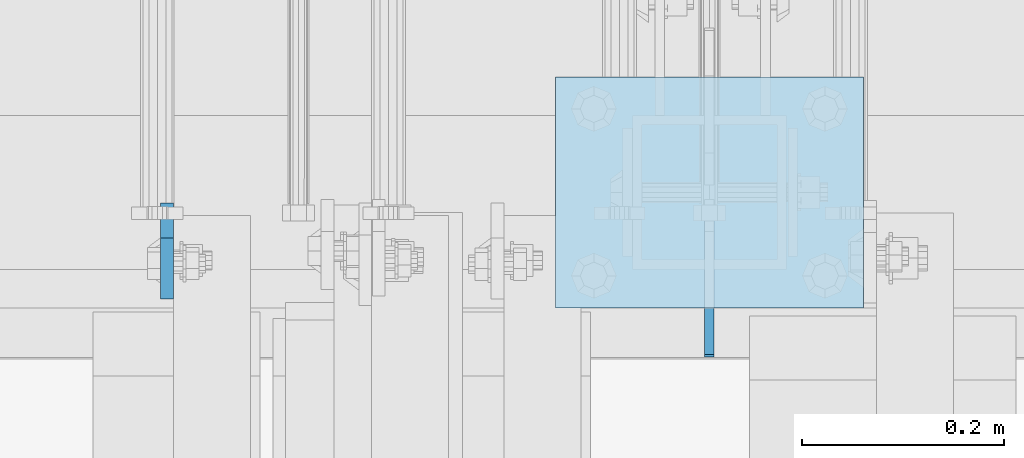
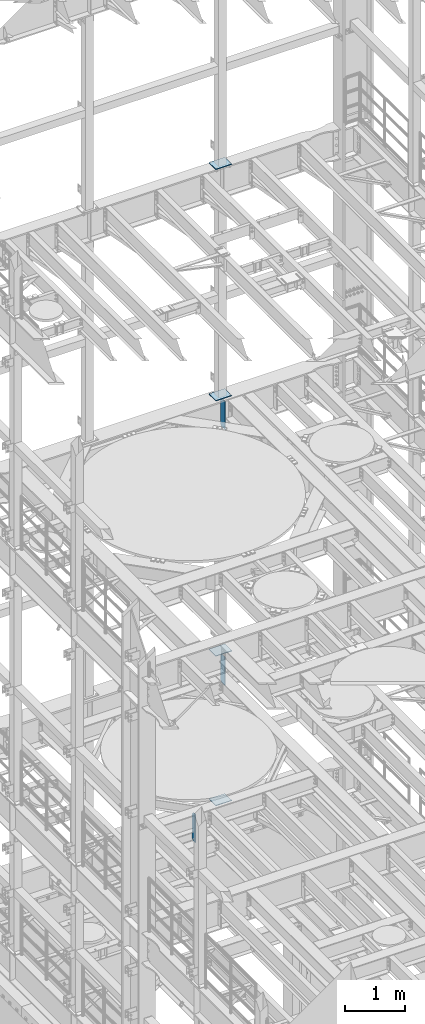
# One storey, part 1799 of 1876: 7 plates, 7 elements without a shape of their own.
"""IFC2X3 building model written with IfcOpenShell, lengths in millimetres."""

from ifc_helpers import new_model, si_unit, frame, origin_with_axes, place, context, subcontext, project, spatial, faceted_brep, material, type_object, element, aggregate, save


model = new_model("IFC2X3")

# Units and contexts
model_context = context("Model", 3, precision=1e-05, world=origin_with_axes())
body_context = subcontext(model_context, "Body", "Model", "MODEL_VIEW")
ifc_project = project(units=[si_unit("LENGTHUNIT", "METRE", prefix="MILLI"), si_unit("AREAUNIT", "SQUARE_METRE"), si_unit("VOLUMEUNIT", "CUBIC_METRE"), si_unit("MASSUNIT", "GRAM", prefix="KILO"), si_unit("TIMEUNIT", "SECOND"), si_unit("PLANEANGLEUNIT", "RADIAN"), si_unit("SOLIDANGLEUNIT", "STERADIAN"), si_unit("THERMODYNAMICTEMPERATUREUNIT", "DEGREE_CELSIUS"), si_unit("LUMINOUSINTENSITYUNIT", "LUMEN")], contexts=[model_context])

# Site, building, storey
site_placement = place(None, origin_with_axes())
site = spatial("IfcSite", under=ifc_project, at=site_placement, CompositionType="ELEMENT")
building_placement = place(site_placement, origin_with_axes())
building = spatial("IfcBuilding", under=site, at=building_placement, Name="Undefined", CompositionType="ELEMENT")
storey_placement = place(building_placement, origin_with_axes())
storey = spatial("IfcBuildingStorey", under=building, at=storey_placement, Name="Undefined", CompositionType="ELEMENT", Elevation=0.0)

# Assembly, plate
assembly_1_placement = place(storey_placement, origin_with_axes())
assembly_1 = element("IfcElementAssembly", 1, at=assembly_1_placement, inside=storey, Name="BEAM", AssemblyPlace="NOTDEFINED", PredefinedType="RIGID_FRAME")
ifc_material = material(Name="STEEL/A36")
plate_type_1 = type_object("IfcPlateType", PredefinedType="NOTDEFINED")
plate_1_placement = place(assembly_1_placement, frame((4543.42499990463, 13705.68125, 4521.2), z_axis=(0.0, 0.0, 1.0), x_axis=(0.0, -1.0, 0.0)))
plate_1 = element("IfcPlate", 2, at=plate_1_placement, type_object=plate_type_1, material=ifc_material, Name="PLATE", context=body_context, shape_type="Brep", body=[
    faceted_brep([(0.0, -6.34999999999991, 34.9249992370605), (0.0, -6.35000000000036, 538.162475585938), (0.0, 6.35000000000036, 538.162475585938), (0.0, 6.34999999999991, 34.9249992370605), (34.9249992370605, -6.34999999999991, 573.087524414062), (34.9249992370605, 6.34999999999991, 573.087524414062), (95.25, -6.34999999999991, 573.087524414062), (95.25, 6.34999999999991, 573.087524414062), (95.25, -6.35000000000036, 0.0), (95.25, 6.35000000000036, 0.0), (34.9249992370605, -6.34999999999991, 0.0), (34.9249992370605, 6.34999999999991, 0.0)], [[[0, 1, 2, 3]], [[1, 4, 5, 2]], [[4, 6, 7, 5]], [[6, 8, 9, 7]], [[8, 10, 11, 9]], [[10, 0, 3, 11]], [[5, 7, 9, 11, 3, 2]], [[10, 8, 6, 4, 1, 0]]]),
])
aggregate(assembly_1, [plate_1])

assembly_2_placement = place(storey_placement, origin_with_axes())
assembly_2 = element("IfcElementAssembly", 3, at=assembly_2_placement, inside=storey, Name="BEAM", AssemblyPlace="NOTDEFINED", PredefinedType="RIGID_FRAME")
plate_type_2 = type_object("IfcPlateType", PredefinedType="NOTDEFINED")
plate_2_placement = place(assembly_2_placement, frame((5080.0, 13555.6625, 12707.9375), z_axis=(0.0, 0.0, 1.0), x_axis=(0.0, 1.0, 0.0)))
plate_2 = element("IfcPlate", 4, at=plate_2_placement, type_object=plate_type_2, material=ifc_material, Name="PLATE", context=body_context, shape_type="Brep", body=[
    faceted_brep([(0.0, -4.76249999999982, 0.0), (0.0, -4.76249999999982, 574.674987792969), (0.0, 4.76249999999982, 574.674987792969), (0.0, 4.76249999999982, 0.0), (114.299995422363, -4.76249999999982, 574.674987792969), (114.299995422363, 4.76249999999982, 574.674987792969), (152.399993896484, -4.76249999999982, 536.574989318848), (152.399993896484, 4.76249999999982, 536.574989318848), (152.399993896484, -4.76249999999982, 38.0999984741211), (152.399993896484, 4.76249999999982, 38.0999984741211), (114.300003051758, -4.76249999999999, 0.0), (114.300003051758, 4.76249999999999, 0.0)], [[[0, 1, 2, 3]], [[1, 4, 5, 2]], [[4, 6, 7, 5]], [[6, 8, 9, 7]], [[8, 10, 11, 9]], [[10, 0, 3, 11]], [[5, 7, 9, 11, 3, 2]], [[10, 8, 6, 4, 1, 0]]]),
])
aggregate(assembly_2, [plate_2])

assembly_3_placement = place(storey_placement, origin_with_axes())
assembly_3 = element("IfcElementAssembly", 5, at=assembly_3_placement, inside=storey, Name="BEAM", AssemblyPlace="NOTDEFINED", PredefinedType="RIGID_FRAME")
plate_3_placement = place(assembly_3_placement, frame((5080.0, 13553.28125, 7542.2125), z_axis=(0.0, 0.0, 1.0), x_axis=(0.0, 1.0, 0.0)))
plate_3 = element("IfcPlate", 6, at=plate_3_placement, type_object=plate_type_2, material=ifc_material, Name="PLATE", context=body_context, shape_type="Brep", body=[
    faceted_brep([(0.0, -4.76249999999982, 0.0), (0.0, -4.76249999999982, 574.674987792969), (0.0, 4.76249999999982, 574.674987792969), (0.0, 4.76249999999982, 0.0), (114.299995422363, -4.76249999999982, 574.674987792969), (114.299995422363, 4.76249999999982, 574.674987792969), (152.399993896484, -4.76249999999982, 536.574989318848), (152.399993896484, 4.76249999999982, 536.574989318848), (152.399993896484, -4.76249999999982, 38.0999984741211), (152.399993896484, 4.76249999999982, 38.0999984741211), (114.300003051758, -4.76249999999999, 0.0), (114.300003051758, 4.76249999999999, 0.0)], [[[0, 1, 2, 3]], [[1, 4, 5, 2]], [[4, 6, 7, 5]], [[6, 8, 9, 7]], [[8, 10, 11, 9]], [[10, 0, 3, 11]], [[5, 7, 9, 11, 3, 2]], [[10, 8, 6, 4, 1, 0]]]),
])
aggregate(assembly_3, [plate_3])

assembly_4_placement = place(storey_placement, origin_with_axes())
assembly_4 = element("IfcElementAssembly", 7, at=assembly_4_placement, inside=storey, Name="FRAME", AssemblyPlace="NOTDEFINED", PredefinedType="RIGID_FRAME")
plate_type_3 = type_object("IfcPlateType", PredefinedType="NOTDEFINED")
plate_4_placement = place(assembly_4_placement, frame((5232.4, 13601.7, 17989.55), z_axis=(-1.0, 0.0, 0.0), x_axis=(0.0, 1.0, 0.0)))
plate_4 = element("IfcPlate", 8, at=plate_4_placement, type_object=plate_type_3, material=ifc_material, Name="PLATE", context=body_context, shape_type="Brep", body=[
    faceted_brep([(0.0, -6.35000000000036, 0.0), (0.0, -6.35000000000036, 304.799987792969), (0.0, 6.35000000000036, 304.799987792969), (0.0, 6.35000000000036, 0.0), (228.600006103516, -6.34999999999854, 304.799987792969), (228.600006103516, 6.34999999999854, 304.799987792969), (228.600006103516, -6.34999999999854, 0.0), (228.600006103516, 6.34999999999854, 0.0)], [[[0, 1, 2, 3]], [[1, 4, 5, 2]], [[4, 6, 7, 5]], [[6, 0, 3, 7]], [[5, 7, 3, 2]], [[6, 4, 1, 0]]]),
])
aggregate(assembly_4, [plate_4])

assembly_5_placement = place(storey_placement, origin_with_axes())
assembly_5 = element("IfcElementAssembly", 9, at=assembly_5_placement, inside=storey, Name="FRAME", AssemblyPlace="NOTDEFINED", PredefinedType="RIGID_FRAME")
plate_5_placement = place(assembly_5_placement, frame((5232.4, 13601.7, 13315.95), z_axis=(-1.0, 0.0, 0.0), x_axis=(0.0, 1.0, 0.0)))
plate_5 = element("IfcPlate", 10, at=plate_5_placement, type_object=plate_type_3, material=ifc_material, Name="PLATE", context=body_context, shape_type="Brep", body=[
    faceted_brep([(0.0, -6.35000000000036, 0.0), (0.0, -6.35000000000036, 304.799987792969), (0.0, 6.35000000000036, 304.799987792969), (0.0, 6.35000000000036, 0.0), (228.600006103516, -6.34999999999854, 304.799987792969), (228.600006103516, 6.34999999999854, 304.799987792969), (228.600006103516, -6.34999999999854, 0.0), (228.600006103516, 6.34999999999854, 0.0)], [[[0, 1, 2, 3]], [[1, 4, 5, 2]], [[4, 6, 7, 5]], [[6, 0, 3, 7]], [[5, 7, 3, 2]], [[6, 4, 1, 0]]]),
])
aggregate(assembly_5, [plate_5])

assembly_6_placement = place(storey_placement, origin_with_axes())
assembly_6 = element("IfcElementAssembly", 11, at=assembly_6_placement, inside=storey, Name="FRAME", AssemblyPlace="NOTDEFINED", PredefinedType="RIGID_FRAME")
plate_6_placement = place(assembly_6_placement, frame((5232.4, 13601.7, 8159.75), z_axis=(-1.0, 0.0, 0.0), x_axis=(0.0, 1.0, 0.0)))
plate_6 = element("IfcPlate", 12, at=plate_6_placement, type_object=plate_type_3, material=ifc_material, Name="PLATE", context=body_context, shape_type="Brep", body=[
    faceted_brep([(0.0, -6.35000000000036, 0.0), (0.0, -6.35000000000036, 304.799987792969), (0.0, 6.35000000000036, 304.799987792969), (0.0, 6.35000000000036, 0.0), (228.600006103516, -6.34999999999854, 304.799987792969), (228.600006103516, 6.34999999999854, 304.799987792969), (228.600006103516, -6.34999999999854, 0.0), (228.600006103516, 6.34999999999854, 0.0)], [[[0, 1, 2, 3]], [[1, 4, 5, 2]], [[4, 6, 7, 5]], [[6, 0, 3, 7]], [[5, 7, 3, 2]], [[6, 4, 1, 0]]]),
])
aggregate(assembly_6, [plate_6])

assembly_7_placement = place(storey_placement, origin_with_axes())
assembly_7 = element("IfcElementAssembly", 13, at=assembly_7_placement, inside=storey, Name="FRAME", AssemblyPlace="NOTDEFINED", PredefinedType="RIGID_FRAME")
plate_7_placement = place(assembly_7_placement, frame((5232.4, 13601.7, 5137.15), z_axis=(-1.0, 0.0, 0.0), x_axis=(0.0, 1.0, 0.0)))
plate_7 = element("IfcPlate", 14, at=plate_7_placement, type_object=plate_type_3, material=ifc_material, Name="PLATE", context=body_context, shape_type="Brep", body=[
    faceted_brep([(0.0, -6.35000000000036, 0.0), (0.0, -6.35000000000036, 304.799987792969), (0.0, 6.35000000000036, 304.799987792969), (0.0, 6.35000000000036, 0.0), (228.600006103516, -6.34999999999854, 304.799987792969), (228.600006103516, 6.34999999999854, 304.799987792969), (228.600006103516, -6.34999999999854, 0.0), (228.600006103516, 6.34999999999854, 0.0)], [[[0, 1, 2, 3]], [[1, 4, 5, 2]], [[4, 6, 7, 5]], [[6, 0, 3, 7]], [[5, 7, 3, 2]], [[6, 4, 1, 0]]]),
])
aggregate(assembly_7, [plate_7])

save(model, "model.ifc")
